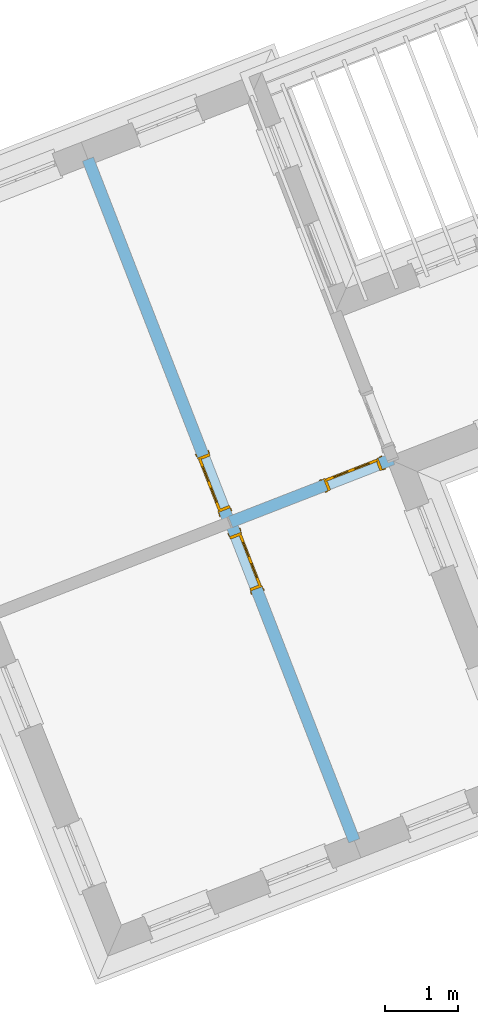
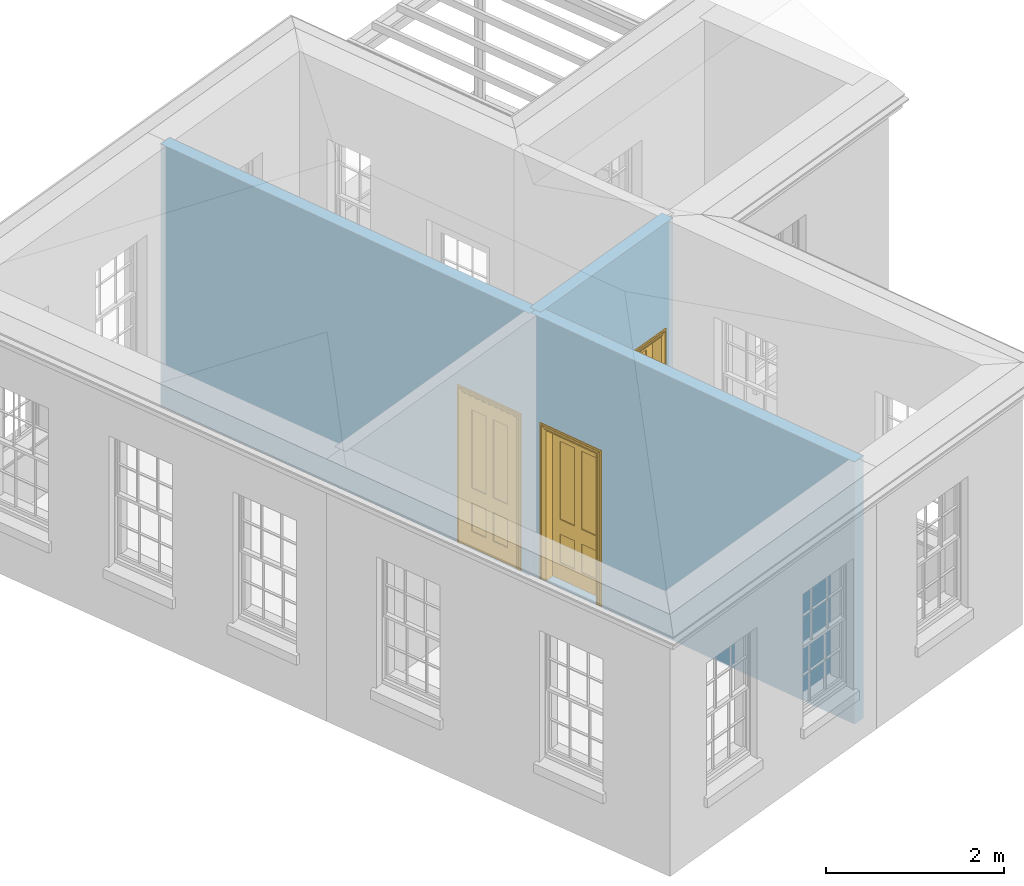
# One storey, part 6 of 11: 3 doors, 3 openings, plus 3 elements that do not belong to this part.
"""IFC2X3 building model written with IfcOpenShell, lengths in metres."""

from ifc_helpers import new_model, si_unit, frame, origin, place, context, subcontext, project, spatial, polyline, outline, extrude, faceted_brep, material, layer, layer_set, layer_usage, element, fill, save


model = new_model("IFC2X3")

# Units and contexts
model_context = context("Model", 3, world=origin())
body_context = subcontext(model_context, "Body", "Model", "MODEL_VIEW")
ifc_project = project(units=[si_unit("PLANEANGLEUNIT", "RADIAN"), si_unit("MASSUNIT", "GRAM", prefix="KILO"), si_unit("FORCEUNIT", "NEWTON", prefix="KILO"), si_unit("LENGTHUNIT", "METRE")], contexts=[model_context])

# Site, building, storey
site_placement = place(None, origin())
site = spatial("IfcSite", under=ifc_project, at=site_placement, CompositionType="ELEMENT")
building_placement = place(None, origin())
building = spatial("IfcBuilding", under=site, at=building_placement, Name="Building plot-3", CompositionType="ELEMENT")
storey_placement = place(None, frame((0.0, 0.0, 5.45)))
storey = spatial("IfcBuildingStorey", under=building, at=storey_placement, Name="Floor 1", CompositionType="ELEMENT", Elevation=5.45)

# Wall, opening, door
ifc_material = material(Name="Masonry")
ifc_layer = layer(ifc_material, 0.16, ventilated=False)
ifc_layer_set = layer_set([ifc_layer], Name="My Wall")
ifc_layer_usage = layer_usage(ifc_layer_set, "AXIS2", "NEGATIVE", 0.08)
wall_1_placement = place(storey_placement, origin())
wall_1 = element("IfcWallStandardCase", 1, at=wall_1_placement, inside=storey, material=ifc_layer_usage, Name="interior", context=body_context, shape_type="SweptSolid", body=[
    extrude(outline(polyline([(39.1203784864176, 47.485269062785), (38.971237565647, 47.4273295619956), (40.6615617640689, 43.0762995407056), (40.8107026848395, 43.134239041495), (39.1203784864176, 47.485269062785)])), origin(), (0.0, 0.0, 1.0), 3.6),
])
opening_1_placement = place(storey_placement, frame((0.0, 0.0, 0.0199999999999996)))
opening_1 = element("IfcOpeningElement", 2, at=opening_1_placement, cuts=wall_1, Name="Opening", ObjectType="Opening", context=body_context, shape_type="SweptSolid", body=[
    extrude(outline(polyline([(39.0364195040351, 47.2595460261288), (39.3261170079822, 46.5138414222763), (39.4752579287527, 46.5717809230657), (39.1855604248056, 47.3174855269182), (39.0364195040351, 47.2595460261288)])), origin(), (0.0, 0.0, 1.0), 2.1),
])
door_1_placement = place(storey_placement, frame((39.1109899644204, 47.2885157765235, 0.0199999999999996), z_axis=(0.0, 0.0, 1.0), x_axis=(0.289697503947082, -0.745704603852509, 0.0)))
door_1 = element("IfcDoor", 3, at=door_1_placement, inside=storey, Name="bedroom inside door", OverallHeight=2.1, OverallWidth=0.8, context=body_context, shape_type="Brep", held_by="IfcProductRepresentation", body=[
    faceted_brep([(0.773, 0.08, 1.895), (0.66, 0.08, 1.895), (0.66, 0.08, 2.073), (0.773, 0.08, 2.073), (0.773, 0.08, 0.82), (0.66, 0.08, 0.82), (0.45, 0.08, 1.895), (0.45, 0.08, 2.073), (0.773, 0.08, 0.62), (0.66, 0.08, 0.62), (0.66, 0.065, 0.82), (0.66, 0.065, 1.895), (0.45, 0.065, 1.895), (0.35, 0.08, 1.895), (0.35, 0.08, 2.073), (0.773, 0.08, 0.225), (0.66, 0.08, 0.225), (0.45, 0.08, 0.62), (0.45, 0.08, 0.82), (0.45, 0.065, 0.82), (0.35, 0.08, 0.82), (0.14, 0.08, 2.073), (0.14, 0.08, 1.895), (0.773, 0.08, 0.0), (0.66, 0.08, 0.0), (0.66, 0.065, 0.225), (0.66, 0.065, 0.62), (0.45, 0.065, 0.62), (0.35, 0.08, 0.62), (0.35, 0.065, 0.82), (0.35, 0.065, 1.895), (0.14, 0.065, 1.895), (0.027, 0.08, 2.073), (0.027, 0.08, 1.895), (0.773, 0.042, 0.0), (0.66, 0.042, 0.0), (0.45, 0.08, 0.0), (0.45, 0.08, 0.225), (0.45, 0.065, 0.225), (0.35, 0.08, 0.225), (0.14, 0.08, 0.82), (0.14, 0.08, 0.62), (0.14, 0.065, 0.82), (0.027, 0.08, 0.82), (0.773, 0.042, 0.225), (0.66, 0.042, 0.225), (0.45, 0.042, 0.0), (0.35, 0.08, 0.0), (0.35, 0.065, 0.225), (0.35, 0.065, 0.62), (0.14, 0.065, 0.62), (0.027, 0.08, 0.62), (0.773, 0.042, 0.62), (0.66, 0.042, 0.62), (0.45, 0.042, 0.225), (0.35, 0.042, 0.0), (0.14, 0.08, 0.225), (0.14, 0.08, 0.0), (0.14, 0.065, 0.225), (0.027, 0.08, 0.225), (0.773, 0.042, 0.82), (0.66, 0.042, 0.82), (0.66, 0.057, 0.62), (0.66, 0.057, 0.225), (0.45, 0.057, 0.225), (0.35, 0.042, 0.225), (0.14, 0.042, 0.0), (0.027, 0.08, 0.0), (0.773, 0.042, 1.895), (0.66, 0.042, 1.895), (0.45, 0.042, 0.62), (0.45, 0.042, 0.82), (0.45, 0.057, 0.62), (0.35, 0.042, 0.62), (0.14, 0.042, 0.225), (0.027, 0.042, 0.0), (0.773, 0.042, 2.073), (0.66, 0.042, 2.073), (0.66, 0.057, 1.895), (0.66, 0.057, 0.82), (0.45, 0.057, 0.82), (0.35, 0.042, 0.82), (0.35, 0.057, 0.62), (0.35, 0.057, 0.225), (0.14, 0.057, 0.225), (0.027, 0.042, 0.225), (0.45, 0.042, 1.895), (0.45, 0.042, 2.073), (0.45, 0.057, 1.895), (0.35, 0.042, 1.895), (0.14, 0.042, 0.82), (0.14, 0.042, 0.62), (0.14, 0.057, 0.62), (0.027, 0.042, 0.62), (0.35, 0.042, 2.073), (0.35, 0.057, 1.895), (0.35, 0.057, 0.82), (0.14, 0.057, 0.82), (0.027, 0.042, 0.82), (0.14, 0.042, 2.073), (0.14, 0.042, 1.895), (0.14, 0.057, 1.895), (0.027, 0.042, 1.895), (0.027, 0.042, 2.073), (0.02, 0.085, 0.0), (0.005, 0.09, 0.0), (0.005, 0.09, 2.095), (0.02, 0.085, 2.08), (0.02, 0.08, 0.0), (0.0, 0.085, 0.0), (0.0, 0.085, 2.1), (0.795, 0.09, 2.095), (0.78, 0.085, 2.08), (0.02, 0.08, 2.08), (0.0, 0.08, 0.0), (-0.032, 0.095, 0.0), (-0.032, 0.095, 2.132), (0.8, 0.085, 2.1), (0.795, 0.09, 0.0), (0.78, 0.085, 0.0), (0.78, 0.08, 2.08), (0.04, 0.04, 0.0), (0.025, 0.04, 0.0), (0.025, 0.04, 2.075), (0.04, 0.04, 2.06), (-0.04, 0.09, 0.0), (-0.04, 0.09, 2.14), (0.832, 0.095, 2.132), (0.8, 0.085, 0.0), (0.78, 0.08, 0.0), (0.8, 0.08, 0.0), (0.86, 0.08, 0.0), (0.86, 0.08, 2.16), (0.8, 0.08, 2.1), (-0.06, 0.08, 2.16), (0.0, 0.08, 2.1), (-0.06, 0.08, 0.0), (-0.04, 0.095, 0.0), (-0.04, 0.095, 2.14), (0.84, 0.09, 2.14), (0.832, 0.095, 0.0), (0.84, 0.09, 0.0), (0.86, 0.095, 0.0), (0.86, 0.095, 2.16), (-0.06, 0.095, 2.16), (-0.06, 0.095, 0.0), (0.84, 0.095, 0.0), (0.84, 0.095, 2.14), (-0.025, -0.095, 0.0), (-0.025, -0.09, 0.0), (-0.025, -0.09, 2.125), (-0.025, -0.095, 2.125), (-0.017, -0.095, 0.0), (-0.017, -0.095, 2.117), (0.825, -0.09, 2.125), (0.825, -0.095, 2.125), (0.825, -0.095, 0.0), (0.845, -0.095, 0.0), (-0.045, -0.095, 2.145), (-0.045, -0.095, 0.0), (0.845, -0.095, 2.145), (0.015, -0.085, 0.0), (0.015, -0.085, 2.085), (0.817, -0.095, 2.117), (0.825, -0.09, 0.0), (0.845, -0.08, 0.0), (0.845, -0.08, 2.145), (-0.045, -0.08, 2.145), (-0.045, -0.08, 0.0), (0.02, -0.09, 0.0), (0.02, -0.09, 2.08), (0.785, -0.085, 2.085), (0.817, -0.095, 0.0), (0.8, -0.08, 0.0), (0.8, -0.08, 2.1), (0.0, -0.08, 2.1), (0.0, -0.08, 0.0), (0.035, -0.085, 0.0), (0.035, -0.085, 2.065), (0.78, -0.09, 2.08), (0.785, -0.085, 0.0), (0.775, 0.04, 2.075), (0.76, 0.04, 2.06), (0.035, -0.08, 2.065), (0.035, -0.08, 0.0), (0.765, -0.085, 2.065), (0.78, -0.09, 0.0), (0.765, -0.08, 0.0), (0.765, -0.08, 2.065), (0.765, -0.085, 0.0), (0.04, -0.08, 2.06), (0.04, -0.08, 0.0), (0.76, -0.08, 2.06), (0.76, -0.08, 0.0), (0.76, 0.04, 0.0), (0.775, 0.04, 0.0), (0.025, 0.08, 0.0), (0.025, 0.08, 2.075), (0.775, 0.08, 0.0), (0.775, 0.08, 2.075)], [[[0, 1, 2, 3]], [[1, 0, 4, 5]], [[1, 6, 7, 2]], [[8, 9, 5, 4]], [[1, 5, 10, 11]], [[6, 1, 11, 12]], [[6, 13, 14, 7]], [[15, 16, 9, 8]], [[9, 17, 18, 5]], [[5, 18, 19, 10]], [[10, 19, 12, 11]], [[18, 6, 12, 19]], [[18, 20, 13, 6]], [[21, 14, 13, 22]], [[23, 24, 16, 15]], [[9, 16, 25, 26]], [[17, 9, 26, 27]], [[17, 28, 20, 18]], [[13, 20, 29, 30]], [[22, 13, 30, 31]], [[32, 21, 22, 33]], [[34, 35, 24, 23]], [[24, 36, 37, 16]], [[16, 37, 38, 25]], [[25, 38, 27, 26]], [[37, 17, 27, 38]], [[37, 39, 28, 17]], [[40, 20, 28, 41]], [[20, 40, 42, 29]], [[31, 30, 29, 42]], [[40, 22, 31, 42]], [[33, 22, 40, 43]], [[35, 34, 44, 45]], [[35, 46, 36, 24]], [[36, 47, 39, 37]], [[28, 39, 48, 49]], [[41, 28, 49, 50]], [[43, 40, 41, 51]], [[45, 44, 52, 53]], [[46, 35, 45, 54]], [[46, 55, 47, 36]], [[56, 39, 47, 57]], [[39, 56, 58, 48]], [[50, 49, 48, 58]], [[56, 41, 50, 58]], [[51, 41, 56, 59]], [[53, 52, 60, 61]], [[45, 53, 62, 63]], [[54, 45, 63, 64]], [[55, 46, 54, 65]], [[55, 66, 57, 47]], [[59, 56, 57, 67]], [[61, 60, 68, 69]], [[70, 53, 61, 71]], [[53, 70, 72, 62]], [[72, 64, 63, 62]], [[70, 54, 64, 72]], [[65, 54, 70, 73]], [[65, 74, 66, 55]], [[67, 57, 66, 75]], [[69, 68, 76, 77]], [[61, 69, 78, 79]], [[71, 61, 79, 80]], [[73, 70, 71, 81]], [[65, 73, 82, 83]], [[74, 65, 83, 84]], [[74, 85, 75, 66]], [[86, 69, 77, 87]], [[69, 86, 88, 78]], [[88, 80, 79, 78]], [[86, 71, 80, 88]], [[81, 71, 86, 89]], [[73, 81, 90, 91]], [[73, 91, 92, 82]], [[83, 82, 92, 84]], [[91, 74, 84, 92]], [[91, 93, 85, 74]], [[89, 86, 87, 94]], [[81, 89, 95, 96]], [[90, 81, 96, 97]], [[90, 98, 93, 91]], [[94, 99, 100, 89]], [[89, 100, 101, 95]], [[101, 97, 96, 95]], [[100, 90, 97, 101]], [[100, 102, 98, 90]], [[99, 103, 102, 100]], [[32, 103, 99, 21]], [[102, 103, 32, 33]], [[98, 102, 33, 43]], [[21, 99, 94, 14]], [[94, 87, 7, 14]], [[7, 87, 77, 2]], [[76, 3, 2, 77]], [[43, 51, 93, 98]], [[51, 59, 85, 93]], [[67, 75, 85, 59]], [[34, 23, 15, 44]], [[44, 15, 8, 52]], [[52, 8, 4, 60]], [[0, 68, 60, 4]], [[0, 3, 76, 68]], [[104, 105, 106, 107]], [[104, 108, 109, 105]], [[105, 109, 110, 106]], [[107, 106, 111, 112]], [[107, 113, 108, 104]], [[114, 109, 108]], [[109, 115, 116, 110]], [[106, 110, 117, 111]], [[112, 111, 118, 119]], [[113, 107, 112, 120]], [[121, 122, 123, 124]], [[115, 109, 114, 125]], [[115, 125, 126, 116]], [[110, 116, 127, 117]], [[111, 117, 128, 118]], [[118, 128, 129, 119]], [[120, 112, 119, 129]], [[130, 129, 128]], [[130, 131, 132, 133]], [[133, 132, 134, 135]], [[135, 134, 136, 114]], [[136, 125, 114]], [[125, 137, 138, 126]], [[116, 126, 139, 127]], [[117, 127, 140, 128]], [[141, 130, 128, 140]], [[131, 130, 141]], [[131, 142, 143, 132]], [[132, 143, 144, 134]], [[134, 144, 145, 136]], [[137, 125, 136, 145]], [[143, 142, 146]], [[143, 146, 147]], [[137, 145, 144]], [[143, 147, 138]], [[138, 137, 144]], [[143, 138, 144]], [[126, 138, 147, 139]], [[127, 139, 141, 140]], [[142, 131, 141, 146]], [[139, 147, 146, 141]], [[148, 149, 150, 151]], [[149, 152, 153, 150]], [[151, 150, 154, 155]], [[155, 156, 157]], [[158, 159, 148]], [[158, 148, 151]], [[155, 157, 160]], [[158, 151, 155]], [[155, 160, 158]], [[152, 161, 162, 153]], [[150, 153, 163, 154]], [[155, 154, 164, 156]], [[156, 164, 165, 157]], [[157, 165, 166, 160]], [[160, 166, 167, 158]], [[158, 167, 168, 159]], [[161, 169, 170, 162]], [[153, 162, 171, 163]], [[154, 163, 172, 164]], [[165, 164, 173]], [[165, 173, 174, 166]], [[166, 174, 175, 167]], [[167, 175, 176, 168]], [[169, 177, 178, 170]], [[162, 170, 179, 171]], [[163, 171, 180, 172]], [[172, 180, 173, 164]], [[124, 123, 181, 182]], [[183, 178, 177, 184]], [[170, 178, 185, 179]], [[171, 179, 186, 180]], [[187, 173, 180]], [[185, 188, 187, 189]], [[188, 185, 178, 183]], [[179, 185, 189, 186]], [[189, 187, 180, 186]], [[190, 183, 184, 191]], [[192, 188, 183, 190]], [[191, 184, 122, 121]], [[124, 190, 191, 121]], [[193, 187, 188, 192]], [[182, 192, 190, 124]], [[184, 176, 122]], [[194, 195, 187, 193]], [[192, 182, 194, 193]], [[161, 176, 184]], [[114, 108, 122, 176]], [[173, 187, 195]], [[152, 149, 176, 161]], [[169, 161, 184, 177]], [[196, 122, 108]], [[176, 175, 135, 114]], [[173, 195, 129, 130]], [[176, 149, 168]], [[123, 122, 196, 197]], [[196, 108, 113, 197]], [[175, 174, 133, 135]], [[198, 129, 195]], [[133, 174, 173, 130]], [[159, 168, 149, 148]], [[181, 123, 197, 199]], [[197, 113, 120, 199]], [[199, 120, 129, 198]], [[195, 181, 199, 198]], [[195, 194, 182, 181]]]),
])
fill(opening_1, door_1)

wall_2_placement = place(storey_placement, origin())
wall_2 = element("IfcWallStandardCase", 4, at=wall_2_placement, inside=storey, material=ifc_layer_usage, Name="interior", context=body_context, shape_type="SweptSolid", body=[
    extrude(outline(polyline([(39.0168039634303, 47.5308564337978), (39.0748120886343, 47.3817421909828), (41.2879062614912, 48.2426756701993), (41.2298981362872, 48.3917899130143), (39.0168039634303, 47.5308564337978)])), origin(), (0.0, 0.0, 1.0), 3.6),
])
opening_2_placement = place(storey_placement, frame((0.0, 0.0, 0.0199999999999996)))
opening_2 = element("IfcOpeningElement", 5, at=opening_2_placement, cuts=wall_2, Name="Opening", ObjectType="Opening", context=body_context, shape_type="SweptSolid", body=[
    extrude(outline(polyline([(40.374581524249, 47.8873759033243), (41.1201527383243, 48.1774165293447), (41.0621446131202, 48.3265307721597), (40.3165733990449, 48.0364901461393), (40.374581524249, 47.8873759033243)])), origin(), (0.0, 0.0, 1.0), 2.1),
])
door_2_placement = place(storey_placement, frame((40.345577461647, 47.9619330247318, 0.0199999999999996), z_axis=(0.0, 0.0, 1.0), x_axis=(0.745571214075284, 0.290040626020399, 0.0)))
door_2 = element("IfcDoor", 6, at=door_2_placement, inside=storey, Name="circulation inside door", OverallHeight=2.1, OverallWidth=0.8, context=body_context, shape_type="Brep", held_by="IfcProductRepresentation", body=[
    faceted_brep([(0.773, 0.08, 1.895), (0.66, 0.08, 1.895), (0.66, 0.08, 2.073), (0.773, 0.08, 2.073), (0.773, 0.08, 0.82), (0.66, 0.08, 0.82), (0.45, 0.08, 1.895), (0.45, 0.08, 2.073), (0.773, 0.08, 0.62), (0.66, 0.08, 0.62), (0.66, 0.065, 0.82), (0.66, 0.065, 1.895), (0.45, 0.065, 1.895), (0.35, 0.08, 1.895), (0.35, 0.08, 2.073), (0.773, 0.08, 0.225), (0.66, 0.08, 0.225), (0.45, 0.08, 0.62), (0.45, 0.08, 0.82), (0.45, 0.065, 0.82), (0.35, 0.08, 0.82), (0.14, 0.08, 2.073), (0.14, 0.08, 1.895), (0.773, 0.08, 0.0), (0.66, 0.08, 0.0), (0.66, 0.065, 0.225), (0.66, 0.065, 0.62), (0.45, 0.065, 0.62), (0.35, 0.08, 0.62), (0.35, 0.065, 0.82), (0.35, 0.065, 1.895), (0.14, 0.065, 1.895), (0.027, 0.08, 2.073), (0.027, 0.08, 1.895), (0.773, 0.042, 0.0), (0.66, 0.042, 0.0), (0.45, 0.08, 0.0), (0.45, 0.08, 0.225), (0.45, 0.065, 0.225), (0.35, 0.08, 0.225), (0.14, 0.08, 0.82), (0.14, 0.08, 0.62), (0.14, 0.065, 0.82), (0.027, 0.08, 0.82), (0.773, 0.042, 0.225), (0.66, 0.042, 0.225), (0.45, 0.042, 0.0), (0.35, 0.08, 0.0), (0.35, 0.065, 0.225), (0.35, 0.065, 0.62), (0.14, 0.065, 0.62), (0.027, 0.08, 0.62), (0.773, 0.042, 0.62), (0.66, 0.042, 0.62), (0.45, 0.042, 0.225), (0.35, 0.042, 0.0), (0.14, 0.08, 0.225), (0.14, 0.08, 0.0), (0.14, 0.065, 0.225), (0.027, 0.08, 0.225), (0.773, 0.042, 0.82), (0.66, 0.042, 0.82), (0.66, 0.057, 0.62), (0.66, 0.057, 0.225), (0.45, 0.057, 0.225), (0.35, 0.042, 0.225), (0.14, 0.042, 0.0), (0.027, 0.08, 0.0), (0.773, 0.042, 1.895), (0.66, 0.042, 1.895), (0.45, 0.042, 0.62), (0.45, 0.042, 0.82), (0.45, 0.057, 0.62), (0.35, 0.042, 0.62), (0.14, 0.042, 0.225), (0.027, 0.042, 0.0), (0.773, 0.042, 2.073), (0.66, 0.042, 2.073), (0.66, 0.057, 1.895), (0.66, 0.057, 0.82), (0.45, 0.057, 0.82), (0.35, 0.042, 0.82), (0.35, 0.057, 0.62), (0.35, 0.057, 0.225), (0.14, 0.057, 0.225), (0.027, 0.042, 0.225), (0.45, 0.042, 1.895), (0.45, 0.042, 2.073), (0.45, 0.057, 1.895), (0.35, 0.042, 1.895), (0.14, 0.042, 0.82), (0.14, 0.042, 0.62), (0.14, 0.057, 0.62), (0.027, 0.042, 0.62), (0.35, 0.042, 2.073), (0.35, 0.057, 1.895), (0.35, 0.057, 0.82), (0.14, 0.057, 0.82), (0.027, 0.042, 0.82), (0.14, 0.042, 2.073), (0.14, 0.042, 1.895), (0.14, 0.057, 1.895), (0.027, 0.042, 1.895), (0.027, 0.042, 2.073), (0.02, 0.085, 0.0), (0.005, 0.09, 0.0), (0.005, 0.09, 2.095), (0.02, 0.085, 2.08), (0.02, 0.08, 0.0), (0.0, 0.085, 0.0), (0.0, 0.085, 2.1), (0.795, 0.09, 2.095), (0.78, 0.085, 2.08), (0.02, 0.08, 2.08), (0.0, 0.08, 0.0), (-0.032, 0.095, 0.0), (-0.032, 0.095, 2.132), (0.8, 0.085, 2.1), (0.795, 0.09, 0.0), (0.78, 0.085, 0.0), (0.78, 0.08, 2.08), (0.04, 0.04, 0.0), (0.025, 0.04, 0.0), (0.025, 0.04, 2.075), (0.04, 0.04, 2.06), (-0.04, 0.09, 0.0), (-0.04, 0.09, 2.14), (0.832, 0.095, 2.132), (0.8, 0.085, 0.0), (0.78, 0.08, 0.0), (0.8, 0.08, 0.0), (0.86, 0.08, 0.0), (0.86, 0.08, 2.16), (0.8, 0.08, 2.1), (-0.06, 0.08, 2.16), (0.0, 0.08, 2.1), (-0.06, 0.08, 0.0), (-0.04, 0.095, 0.0), (-0.04, 0.095, 2.14), (0.84, 0.09, 2.14), (0.832, 0.095, 0.0), (0.84, 0.09, 0.0), (0.86, 0.095, 0.0), (0.86, 0.095, 2.16), (-0.06, 0.095, 2.16), (-0.06, 0.095, 0.0), (0.84, 0.095, 0.0), (0.84, 0.095, 2.14), (-0.025, -0.095, 0.0), (-0.025, -0.09, 0.0), (-0.025, -0.09, 2.125), (-0.025, -0.095, 2.125), (-0.017, -0.095, 0.0), (-0.017, -0.095, 2.117), (0.825, -0.09, 2.125), (0.825, -0.095, 2.125), (0.825, -0.095, 0.0), (0.845, -0.095, 0.0), (-0.045, -0.095, 2.145), (-0.045, -0.095, 0.0), (0.845, -0.095, 2.145), (0.015, -0.085, 0.0), (0.015, -0.085, 2.085), (0.817, -0.095, 2.117), (0.825, -0.09, 0.0), (0.845, -0.08, 0.0), (0.845, -0.08, 2.145), (-0.045, -0.08, 2.145), (-0.045, -0.08, 0.0), (0.02, -0.09, 0.0), (0.02, -0.09, 2.08), (0.785, -0.085, 2.085), (0.817, -0.095, 0.0), (0.8, -0.08, 0.0), (0.8, -0.08, 2.1), (0.0, -0.08, 2.1), (0.0, -0.08, 0.0), (0.035, -0.085, 0.0), (0.035, -0.085, 2.065), (0.78, -0.09, 2.08), (0.785, -0.085, 0.0), (0.775, 0.04, 2.075), (0.76, 0.04, 2.06), (0.035, -0.08, 2.065), (0.035, -0.08, 0.0), (0.765, -0.085, 2.065), (0.78, -0.09, 0.0), (0.765, -0.08, 0.0), (0.765, -0.08, 2.065), (0.765, -0.085, 0.0), (0.04, -0.08, 2.06), (0.04, -0.08, 0.0), (0.76, -0.08, 2.06), (0.76, -0.08, 0.0), (0.76, 0.04, 0.0), (0.775, 0.04, 0.0), (0.025, 0.08, 0.0), (0.025, 0.08, 2.075), (0.775, 0.08, 0.0), (0.775, 0.08, 2.075)], [[[0, 1, 2, 3]], [[1, 0, 4, 5]], [[1, 6, 7, 2]], [[8, 9, 5, 4]], [[1, 5, 10, 11]], [[6, 1, 11, 12]], [[6, 13, 14, 7]], [[15, 16, 9, 8]], [[9, 17, 18, 5]], [[5, 18, 19, 10]], [[10, 19, 12, 11]], [[18, 6, 12, 19]], [[18, 20, 13, 6]], [[21, 14, 13, 22]], [[23, 24, 16, 15]], [[9, 16, 25, 26]], [[17, 9, 26, 27]], [[17, 28, 20, 18]], [[13, 20, 29, 30]], [[22, 13, 30, 31]], [[32, 21, 22, 33]], [[34, 35, 24, 23]], [[24, 36, 37, 16]], [[16, 37, 38, 25]], [[25, 38, 27, 26]], [[37, 17, 27, 38]], [[37, 39, 28, 17]], [[40, 20, 28, 41]], [[20, 40, 42, 29]], [[31, 30, 29, 42]], [[40, 22, 31, 42]], [[33, 22, 40, 43]], [[35, 34, 44, 45]], [[35, 46, 36, 24]], [[36, 47, 39, 37]], [[28, 39, 48, 49]], [[41, 28, 49, 50]], [[43, 40, 41, 51]], [[45, 44, 52, 53]], [[46, 35, 45, 54]], [[46, 55, 47, 36]], [[56, 39, 47, 57]], [[39, 56, 58, 48]], [[50, 49, 48, 58]], [[56, 41, 50, 58]], [[51, 41, 56, 59]], [[53, 52, 60, 61]], [[45, 53, 62, 63]], [[54, 45, 63, 64]], [[55, 46, 54, 65]], [[55, 66, 57, 47]], [[59, 56, 57, 67]], [[61, 60, 68, 69]], [[70, 53, 61, 71]], [[53, 70, 72, 62]], [[72, 64, 63, 62]], [[70, 54, 64, 72]], [[65, 54, 70, 73]], [[65, 74, 66, 55]], [[67, 57, 66, 75]], [[69, 68, 76, 77]], [[61, 69, 78, 79]], [[71, 61, 79, 80]], [[73, 70, 71, 81]], [[65, 73, 82, 83]], [[74, 65, 83, 84]], [[74, 85, 75, 66]], [[86, 69, 77, 87]], [[69, 86, 88, 78]], [[88, 80, 79, 78]], [[86, 71, 80, 88]], [[81, 71, 86, 89]], [[73, 81, 90, 91]], [[73, 91, 92, 82]], [[83, 82, 92, 84]], [[91, 74, 84, 92]], [[91, 93, 85, 74]], [[89, 86, 87, 94]], [[81, 89, 95, 96]], [[90, 81, 96, 97]], [[90, 98, 93, 91]], [[94, 99, 100, 89]], [[89, 100, 101, 95]], [[101, 97, 96, 95]], [[100, 90, 97, 101]], [[100, 102, 98, 90]], [[99, 103, 102, 100]], [[32, 103, 99, 21]], [[102, 103, 32, 33]], [[98, 102, 33, 43]], [[21, 99, 94, 14]], [[94, 87, 7, 14]], [[7, 87, 77, 2]], [[76, 3, 2, 77]], [[43, 51, 93, 98]], [[51, 59, 85, 93]], [[67, 75, 85, 59]], [[34, 23, 15, 44]], [[44, 15, 8, 52]], [[52, 8, 4, 60]], [[0, 68, 60, 4]], [[0, 3, 76, 68]], [[104, 105, 106, 107]], [[104, 108, 109, 105]], [[105, 109, 110, 106]], [[107, 106, 111, 112]], [[107, 113, 108, 104]], [[114, 109, 108]], [[109, 115, 116, 110]], [[106, 110, 117, 111]], [[112, 111, 118, 119]], [[113, 107, 112, 120]], [[121, 122, 123, 124]], [[115, 109, 114, 125]], [[115, 125, 126, 116]], [[110, 116, 127, 117]], [[111, 117, 128, 118]], [[118, 128, 129, 119]], [[120, 112, 119, 129]], [[130, 129, 128]], [[130, 131, 132, 133]], [[133, 132, 134, 135]], [[135, 134, 136, 114]], [[136, 125, 114]], [[125, 137, 138, 126]], [[116, 126, 139, 127]], [[117, 127, 140, 128]], [[141, 130, 128, 140]], [[131, 130, 141]], [[131, 142, 143, 132]], [[132, 143, 144, 134]], [[134, 144, 145, 136]], [[137, 125, 136, 145]], [[143, 142, 146]], [[143, 146, 147]], [[137, 145, 144]], [[143, 147, 138]], [[138, 137, 144]], [[143, 138, 144]], [[126, 138, 147, 139]], [[127, 139, 141, 140]], [[142, 131, 141, 146]], [[139, 147, 146, 141]], [[148, 149, 150, 151]], [[149, 152, 153, 150]], [[151, 150, 154, 155]], [[155, 156, 157]], [[158, 159, 148]], [[158, 148, 151]], [[155, 157, 160]], [[158, 151, 155]], [[155, 160, 158]], [[152, 161, 162, 153]], [[150, 153, 163, 154]], [[155, 154, 164, 156]], [[156, 164, 165, 157]], [[157, 165, 166, 160]], [[160, 166, 167, 158]], [[158, 167, 168, 159]], [[161, 169, 170, 162]], [[153, 162, 171, 163]], [[154, 163, 172, 164]], [[165, 164, 173]], [[165, 173, 174, 166]], [[166, 174, 175, 167]], [[167, 175, 176, 168]], [[169, 177, 178, 170]], [[162, 170, 179, 171]], [[163, 171, 180, 172]], [[172, 180, 173, 164]], [[124, 123, 181, 182]], [[183, 178, 177, 184]], [[170, 178, 185, 179]], [[171, 179, 186, 180]], [[187, 173, 180]], [[185, 188, 187, 189]], [[188, 185, 178, 183]], [[179, 185, 189, 186]], [[189, 187, 180, 186]], [[190, 183, 184, 191]], [[192, 188, 183, 190]], [[191, 184, 122, 121]], [[124, 190, 191, 121]], [[193, 187, 188, 192]], [[182, 192, 190, 124]], [[184, 176, 122]], [[194, 195, 187, 193]], [[192, 182, 194, 193]], [[161, 176, 184]], [[114, 108, 122, 176]], [[173, 187, 195]], [[152, 149, 176, 161]], [[169, 161, 184, 177]], [[196, 122, 108]], [[176, 175, 135, 114]], [[173, 195, 129, 130]], [[176, 149, 168]], [[123, 122, 196, 197]], [[196, 108, 113, 197]], [[175, 174, 133, 135]], [[198, 129, 195]], [[133, 174, 173, 130]], [[159, 168, 149, 148]], [[181, 123, 197, 199]], [[197, 113, 120, 199]], [[199, 120, 129, 198]], [[195, 181, 199, 198]], [[195, 194, 182, 181]]]),
])
fill(opening_2, door_2)

wall_3_placement = place(storey_placement, origin())
wall_3 = element("IfcWallStandardCase", 7, at=wall_3_placement, inside=storey, material=ifc_layer_usage, Name="interior", context=body_context, shape_type="SweptSolid", body=[
    extrude(outline(polyline([(38.9540041218129, 47.4205859407522), (39.1031183646279, 47.4785940659562), (37.1736465066948, 52.4384463989949), (37.0245322638798, 52.3804382737909), (38.9540041218129, 47.4205859407522)])), origin(), (0.0, 0.0, 1.0), 3.6),
])
opening_3_placement = place(storey_placement, frame((0.0, 0.0, 0.0199999999999996)))
opening_3 = element("IfcOpeningElement", 8, at=opening_3_placement, cuts=wall_3, Name="Opening", ObjectType="Opening", context=body_context, shape_type="SweptSolid", body=[
    extrude(outline(polyline([(39.0378592237733, 47.6463475891232), (38.7478185977529, 48.3919188031985), (38.5987043549379, 48.3339106779944), (38.8887449809583, 47.5883394639191), (39.0378592237733, 47.6463475891232)])), origin(), (0.0, 0.0, 1.0), 2.1),
])
door_3_placement = place(storey_placement, frame((38.9633021023658, 47.6173435265211, 0.0199999999999996), z_axis=(0.0, 0.0, 1.0), x_axis=(-0.290040626020392, 0.745571214075291, 0.0)))
door_3 = element("IfcDoor", 9, at=door_3_placement, inside=storey, Name="bedroom inside door", OverallHeight=2.1, OverallWidth=0.8, context=body_context, shape_type="Brep", held_by="IfcProductRepresentation", body=[
    faceted_brep([(0.773, 0.08, 1.895), (0.66, 0.08, 1.895), (0.66, 0.08, 2.073), (0.773, 0.08, 2.073), (0.773, 0.08, 0.82), (0.66, 0.08, 0.82), (0.45, 0.08, 1.895), (0.45, 0.08, 2.073), (0.773, 0.08, 0.62), (0.66, 0.08, 0.62), (0.66, 0.065, 0.82), (0.66, 0.065, 1.895), (0.45, 0.065, 1.895), (0.35, 0.08, 1.895), (0.35, 0.08, 2.073), (0.773, 0.08, 0.225), (0.66, 0.08, 0.225), (0.45, 0.08, 0.62), (0.45, 0.08, 0.82), (0.45, 0.065, 0.82), (0.35, 0.08, 0.82), (0.14, 0.08, 2.073), (0.14, 0.08, 1.895), (0.773, 0.08, 0.0), (0.66, 0.08, 0.0), (0.66, 0.065, 0.225), (0.66, 0.065, 0.62), (0.45, 0.065, 0.62), (0.35, 0.08, 0.62), (0.35, 0.065, 0.82), (0.35, 0.065, 1.895), (0.14, 0.065, 1.895), (0.027, 0.08, 2.073), (0.027, 0.08, 1.895), (0.773, 0.042, 0.0), (0.66, 0.042, 0.0), (0.45, 0.08, 0.0), (0.45, 0.08, 0.225), (0.45, 0.065, 0.225), (0.35, 0.08, 0.225), (0.14, 0.08, 0.82), (0.14, 0.08, 0.62), (0.14, 0.065, 0.82), (0.027, 0.08, 0.82), (0.773, 0.042, 0.225), (0.66, 0.042, 0.225), (0.45, 0.042, 0.0), (0.35, 0.08, 0.0), (0.35, 0.065, 0.225), (0.35, 0.065, 0.62), (0.14, 0.065, 0.62), (0.027, 0.08, 0.62), (0.773, 0.042, 0.62), (0.66, 0.042, 0.62), (0.45, 0.042, 0.225), (0.35, 0.042, 0.0), (0.14, 0.08, 0.225), (0.14, 0.08, 0.0), (0.14, 0.065, 0.225), (0.027, 0.08, 0.225), (0.773, 0.042, 0.82), (0.66, 0.042, 0.82), (0.66, 0.057, 0.62), (0.66, 0.057, 0.225), (0.45, 0.057, 0.225), (0.35, 0.042, 0.225), (0.14, 0.042, 0.0), (0.027, 0.08, 0.0), (0.773, 0.042, 1.895), (0.66, 0.042, 1.895), (0.45, 0.042, 0.62), (0.45, 0.042, 0.82), (0.45, 0.057, 0.62), (0.35, 0.042, 0.62), (0.14, 0.042, 0.225), (0.027, 0.042, 0.0), (0.773, 0.042, 2.073), (0.66, 0.042, 2.073), (0.66, 0.057, 1.895), (0.66, 0.057, 0.82), (0.45, 0.057, 0.82), (0.35, 0.042, 0.82), (0.35, 0.057, 0.62), (0.35, 0.057, 0.225), (0.14, 0.057, 0.225), (0.027, 0.042, 0.225), (0.45, 0.042, 1.895), (0.45, 0.042, 2.073), (0.45, 0.057, 1.895), (0.35, 0.042, 1.895), (0.14, 0.042, 0.82), (0.14, 0.042, 0.62), (0.14, 0.057, 0.62), (0.027, 0.042, 0.62), (0.35, 0.042, 2.073), (0.35, 0.057, 1.895), (0.35, 0.057, 0.82), (0.14, 0.057, 0.82), (0.027, 0.042, 0.82), (0.14, 0.042, 2.073), (0.14, 0.042, 1.895), (0.14, 0.057, 1.895), (0.027, 0.042, 1.895), (0.027, 0.042, 2.073), (0.02, 0.085, 0.0), (0.005, 0.09, 0.0), (0.005, 0.09, 2.095), (0.02, 0.085, 2.08), (0.02, 0.08, 0.0), (0.0, 0.085, 0.0), (0.0, 0.085, 2.1), (0.795, 0.09, 2.095), (0.78, 0.085, 2.08), (0.02, 0.08, 2.08), (0.0, 0.08, 0.0), (-0.032, 0.095, 0.0), (-0.032, 0.095, 2.132), (0.8, 0.085, 2.1), (0.795, 0.09, 0.0), (0.78, 0.085, 0.0), (0.78, 0.08, 2.08), (0.04, 0.04, 0.0), (0.025, 0.04, 0.0), (0.025, 0.04, 2.075), (0.04, 0.04, 2.06), (-0.04, 0.09, 0.0), (-0.04, 0.09, 2.14), (0.832, 0.095, 2.132), (0.8, 0.085, 0.0), (0.78, 0.08, 0.0), (0.8, 0.08, 0.0), (0.86, 0.08, 0.0), (0.86, 0.08, 2.16), (0.8, 0.08, 2.1), (-0.06, 0.08, 2.16), (0.0, 0.08, 2.1), (-0.06, 0.08, 0.0), (-0.04, 0.095, 0.0), (-0.04, 0.095, 2.14), (0.84, 0.09, 2.14), (0.832, 0.095, 0.0), (0.84, 0.09, 0.0), (0.86, 0.095, 0.0), (0.86, 0.095, 2.16), (-0.06, 0.095, 2.16), (-0.06, 0.095, 0.0), (0.84, 0.095, 0.0), (0.84, 0.095, 2.14), (-0.025, -0.095, 0.0), (-0.025, -0.09, 0.0), (-0.025, -0.09, 2.125), (-0.025, -0.095, 2.125), (-0.017, -0.095, 0.0), (-0.017, -0.095, 2.117), (0.825, -0.09, 2.125), (0.825, -0.095, 2.125), (0.825, -0.095, 0.0), (0.845, -0.095, 0.0), (-0.045, -0.095, 2.145), (-0.045, -0.095, 0.0), (0.845, -0.095, 2.145), (0.015, -0.085, 0.0), (0.015, -0.085, 2.085), (0.817, -0.095, 2.117), (0.825, -0.09, 0.0), (0.845, -0.08, 0.0), (0.845, -0.08, 2.145), (-0.045, -0.08, 2.145), (-0.045, -0.08, 0.0), (0.02, -0.09, 0.0), (0.02, -0.09, 2.08), (0.785, -0.085, 2.085), (0.817, -0.095, 0.0), (0.8, -0.08, 0.0), (0.8, -0.08, 2.1), (0.0, -0.08, 2.1), (0.0, -0.08, 0.0), (0.035, -0.085, 0.0), (0.035, -0.085, 2.065), (0.78, -0.09, 2.08), (0.785, -0.085, 0.0), (0.775, 0.04, 2.075), (0.76, 0.04, 2.06), (0.035, -0.08, 2.065), (0.035, -0.08, 0.0), (0.765, -0.085, 2.065), (0.78, -0.09, 0.0), (0.765, -0.08, 0.0), (0.765, -0.08, 2.065), (0.765, -0.085, 0.0), (0.04, -0.08, 2.06), (0.04, -0.08, 0.0), (0.76, -0.08, 2.06), (0.76, -0.08, 0.0), (0.76, 0.04, 0.0), (0.775, 0.04, 0.0), (0.025, 0.08, 0.0), (0.025, 0.08, 2.075), (0.775, 0.08, 0.0), (0.775, 0.08, 2.075)], [[[0, 1, 2, 3]], [[1, 0, 4, 5]], [[1, 6, 7, 2]], [[8, 9, 5, 4]], [[1, 5, 10, 11]], [[6, 1, 11, 12]], [[6, 13, 14, 7]], [[15, 16, 9, 8]], [[9, 17, 18, 5]], [[5, 18, 19, 10]], [[10, 19, 12, 11]], [[18, 6, 12, 19]], [[18, 20, 13, 6]], [[21, 14, 13, 22]], [[23, 24, 16, 15]], [[9, 16, 25, 26]], [[17, 9, 26, 27]], [[17, 28, 20, 18]], [[13, 20, 29, 30]], [[22, 13, 30, 31]], [[32, 21, 22, 33]], [[34, 35, 24, 23]], [[24, 36, 37, 16]], [[16, 37, 38, 25]], [[25, 38, 27, 26]], [[37, 17, 27, 38]], [[37, 39, 28, 17]], [[40, 20, 28, 41]], [[20, 40, 42, 29]], [[31, 30, 29, 42]], [[40, 22, 31, 42]], [[33, 22, 40, 43]], [[35, 34, 44, 45]], [[35, 46, 36, 24]], [[36, 47, 39, 37]], [[28, 39, 48, 49]], [[41, 28, 49, 50]], [[43, 40, 41, 51]], [[45, 44, 52, 53]], [[46, 35, 45, 54]], [[46, 55, 47, 36]], [[56, 39, 47, 57]], [[39, 56, 58, 48]], [[50, 49, 48, 58]], [[56, 41, 50, 58]], [[51, 41, 56, 59]], [[53, 52, 60, 61]], [[45, 53, 62, 63]], [[54, 45, 63, 64]], [[55, 46, 54, 65]], [[55, 66, 57, 47]], [[59, 56, 57, 67]], [[61, 60, 68, 69]], [[70, 53, 61, 71]], [[53, 70, 72, 62]], [[72, 64, 63, 62]], [[70, 54, 64, 72]], [[65, 54, 70, 73]], [[65, 74, 66, 55]], [[67, 57, 66, 75]], [[69, 68, 76, 77]], [[61, 69, 78, 79]], [[71, 61, 79, 80]], [[73, 70, 71, 81]], [[65, 73, 82, 83]], [[74, 65, 83, 84]], [[74, 85, 75, 66]], [[86, 69, 77, 87]], [[69, 86, 88, 78]], [[88, 80, 79, 78]], [[86, 71, 80, 88]], [[81, 71, 86, 89]], [[73, 81, 90, 91]], [[73, 91, 92, 82]], [[83, 82, 92, 84]], [[91, 74, 84, 92]], [[91, 93, 85, 74]], [[89, 86, 87, 94]], [[81, 89, 95, 96]], [[90, 81, 96, 97]], [[90, 98, 93, 91]], [[94, 99, 100, 89]], [[89, 100, 101, 95]], [[101, 97, 96, 95]], [[100, 90, 97, 101]], [[100, 102, 98, 90]], [[99, 103, 102, 100]], [[32, 103, 99, 21]], [[102, 103, 32, 33]], [[98, 102, 33, 43]], [[21, 99, 94, 14]], [[94, 87, 7, 14]], [[7, 87, 77, 2]], [[76, 3, 2, 77]], [[43, 51, 93, 98]], [[51, 59, 85, 93]], [[67, 75, 85, 59]], [[34, 23, 15, 44]], [[44, 15, 8, 52]], [[52, 8, 4, 60]], [[0, 68, 60, 4]], [[0, 3, 76, 68]], [[104, 105, 106, 107]], [[104, 108, 109, 105]], [[105, 109, 110, 106]], [[107, 106, 111, 112]], [[107, 113, 108, 104]], [[114, 109, 108]], [[109, 115, 116, 110]], [[106, 110, 117, 111]], [[112, 111, 118, 119]], [[113, 107, 112, 120]], [[121, 122, 123, 124]], [[115, 109, 114, 125]], [[115, 125, 126, 116]], [[110, 116, 127, 117]], [[111, 117, 128, 118]], [[118, 128, 129, 119]], [[120, 112, 119, 129]], [[130, 129, 128]], [[130, 131, 132, 133]], [[133, 132, 134, 135]], [[135, 134, 136, 114]], [[136, 125, 114]], [[125, 137, 138, 126]], [[116, 126, 139, 127]], [[117, 127, 140, 128]], [[141, 130, 128, 140]], [[131, 130, 141]], [[131, 142, 143, 132]], [[132, 143, 144, 134]], [[134, 144, 145, 136]], [[137, 125, 136, 145]], [[143, 142, 146]], [[143, 146, 147]], [[137, 145, 144]], [[143, 147, 138]], [[138, 137, 144]], [[143, 138, 144]], [[126, 138, 147, 139]], [[127, 139, 141, 140]], [[142, 131, 141, 146]], [[139, 147, 146, 141]], [[148, 149, 150, 151]], [[149, 152, 153, 150]], [[151, 150, 154, 155]], [[155, 156, 157]], [[158, 159, 148]], [[158, 148, 151]], [[155, 157, 160]], [[158, 151, 155]], [[155, 160, 158]], [[152, 161, 162, 153]], [[150, 153, 163, 154]], [[155, 154, 164, 156]], [[156, 164, 165, 157]], [[157, 165, 166, 160]], [[160, 166, 167, 158]], [[158, 167, 168, 159]], [[161, 169, 170, 162]], [[153, 162, 171, 163]], [[154, 163, 172, 164]], [[165, 164, 173]], [[165, 173, 174, 166]], [[166, 174, 175, 167]], [[167, 175, 176, 168]], [[169, 177, 178, 170]], [[162, 170, 179, 171]], [[163, 171, 180, 172]], [[172, 180, 173, 164]], [[124, 123, 181, 182]], [[183, 178, 177, 184]], [[170, 178, 185, 179]], [[171, 179, 186, 180]], [[187, 173, 180]], [[185, 188, 187, 189]], [[188, 185, 178, 183]], [[179, 185, 189, 186]], [[189, 187, 180, 186]], [[190, 183, 184, 191]], [[192, 188, 183, 190]], [[191, 184, 122, 121]], [[124, 190, 191, 121]], [[193, 187, 188, 192]], [[182, 192, 190, 124]], [[184, 176, 122]], [[194, 195, 187, 193]], [[192, 182, 194, 193]], [[161, 176, 184]], [[114, 108, 122, 176]], [[173, 187, 195]], [[152, 149, 176, 161]], [[169, 161, 184, 177]], [[196, 122, 108]], [[176, 175, 135, 114]], [[173, 195, 129, 130]], [[176, 149, 168]], [[123, 122, 196, 197]], [[196, 108, 113, 197]], [[175, 174, 133, 135]], [[198, 129, 195]], [[133, 174, 173, 130]], [[159, 168, 149, 148]], [[181, 123, 197, 199]], [[197, 113, 120, 199]], [[199, 120, 129, 198]], [[195, 181, 199, 198]], [[195, 194, 182, 181]]]),
])
fill(opening_3, door_3)

save(model, "model.ifc")
